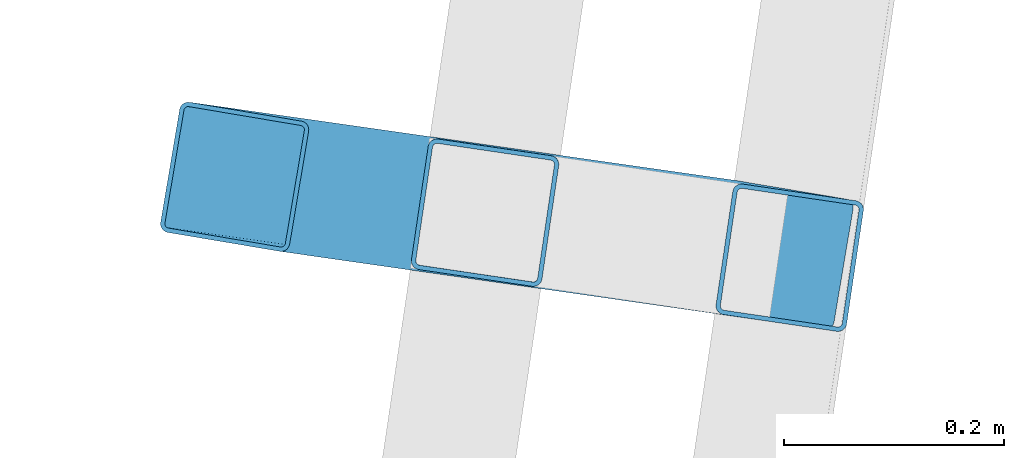
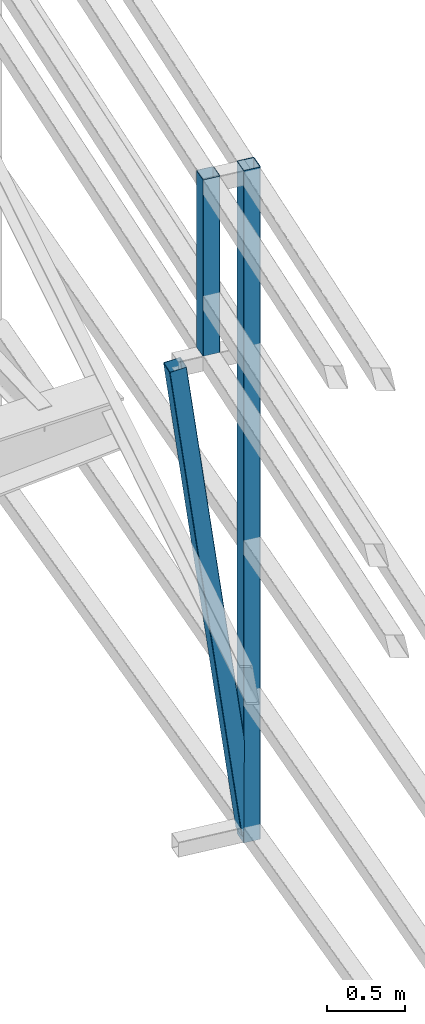
# One storey, part 124 of 215: 2 beams, 1 member, 3 elements without a shape of their own.
"""IFC2X3 building model written with IfcOpenShell, lengths in millimetres."""

from ifc_helpers import new_model, si_unit, frame, origin_with_axes, origin_2d_with_axis, place, context, subcontext, project, spatial, hollow_rectangle, extrude, material, type_object, element, aggregate, save


model = new_model("IFC2X3")

# Units and contexts
model_context = context("Model", 3, precision=1e-05, world=origin_with_axes())
body_context = subcontext(model_context, "Body", "Model", "MODEL_VIEW")
ifc_project = project(units=[si_unit("LENGTHUNIT", "METRE", prefix="MILLI"), si_unit("AREAUNIT", "SQUARE_METRE"), si_unit("VOLUMEUNIT", "CUBIC_METRE"), si_unit("MASSUNIT", "GRAM", prefix="KILO"), si_unit("TIMEUNIT", "SECOND"), si_unit("PLANEANGLEUNIT", "RADIAN"), si_unit("SOLIDANGLEUNIT", "STERADIAN"), si_unit("THERMODYNAMICTEMPERATUREUNIT", "DEGREE_CELSIUS"), si_unit("LUMINOUSINTENSITYUNIT", "LUMEN")], contexts=[model_context])

# Site, building, storey
site_placement = place(None, origin_with_axes())
site = spatial("IfcSite", under=ifc_project, at=site_placement, CompositionType="ELEMENT")
building_placement = place(site_placement, origin_with_axes())
building = spatial("IfcBuilding", under=site, at=building_placement, Name="Undefined", CompositionType="ELEMENT")
storey_placement = place(building_placement, origin_with_axes())
storey = spatial("IfcBuildingStorey", under=building, at=storey_placement, Name="Undefined", CompositionType="ELEMENT", Elevation=0.0)

# Assembly, beam
assembly_1_placement = place(storey_placement, origin_with_axes())
assembly_1 = element("IfcElementAssembly", 1, at=assembly_1_placement, inside=storey, Name="Steel Assembly", AssemblyPlace="NOTDEFINED", PredefinedType="RIGID_FRAME")
ifc_material = material(Name="STEEL/S275JR")
beam_type = type_object("IfcBeamType", PredefinedType="NOTDEFINED")
beam_1_placement = place(assembly_1_placement, frame((153218.497493034, 62408.8072456435, 5582.07346282597), z_axis=(0.989259672851491, -0.146168736978062, 0.0), x_axis=(9.50699999125844e-06, 6.43569999946843e-05, -0.999999997883897)))
beam_1 = element("IfcBeam", 2, at=beam_1_placement, type_object=beam_type, material=ifc_material, Name="LISSE", context=body_context, shape_type="SweptSolid", body=[
    extrude(hollow_rectangle(XDim=120.0, YDim=120.0, WallThickness=4.0, InnerFilletRadius=4.0, OuterFilletRadius=8.0, at=origin_2d_with_axis()), frame((1383.43541020251, -1.87490459654367e-17, 3.97204214758489e-18), z_axis=(-1.0, 0.0, 0.0), x_axis=(-6.93889390390723e-18, -1.0, -3.46944695195361e-18)), (0.0, 0.0, 1.0), 1383.4),
])
aggregate(assembly_1, [beam_1])

assembly_2_placement = place(storey_placement, origin_with_axes())
assembly_2 = element("IfcElementAssembly", 3, at=assembly_2_placement, inside=storey, Name="Steel Assembly", AssemblyPlace="NOTDEFINED", PredefinedType="RIGID_FRAME")
beam_2_placement = place(assembly_2_placement, frame((153495.485152215, 62367.8818838379, 5582.07345771888), z_axis=(0.989259672851491, -0.146168736978062, 0.0), x_axis=(0.0, 0.0, -1.0)))
beam_2 = element("IfcBeam", 4, at=beam_2_placement, type_object=beam_type, material=ifc_material, Name="LISSE", context=body_context, shape_type="SweptSolid", body=[
    extrude(hollow_rectangle(XDim=120.0, YDim=120.0, WallThickness=4.0, InnerFilletRadius=4.0, OuterFilletRadius=8.0, at=origin_2d_with_axis()), frame((5271.47024798367, 0.0, 0.0), z_axis=(-1.0, 0.0, 0.0), x_axis=(-6.93889390390723e-18, -1.0, -3.46944695195361e-18)), (0.0, 0.0, 1.0), 5271.5),
])
aggregate(assembly_2, [beam_2])

# Assembly, member
assembly_3_placement = place(storey_placement, origin_with_axes())
assembly_3 = element("IfcElementAssembly", 5, at=assembly_3_placement, inside=storey, Name="Steel Assembly", AssemblyPlace="NOTDEFINED", PredefinedType="RIGID_FRAME")
member_type = type_object("IfcMemberType", PredefinedType="NOTDEFINED")
member_placement = place(assembly_3_placement, frame((153485.789304556, 62370.6115388793, 370.603214711808), z_axis=(0.977519721024776, -0.164800514004181, 0.131514203003335), x_axis=(-0.130227987007616, 0.0186333370010904, 0.991308968057965)))
member = element("IfcMember", 6, at=member_placement, type_object=member_type, material=ifc_material, Name="LISSE", context=body_context, shape_type="SweptSolid", body=[
    extrude(hollow_rectangle(XDim=120.0, YDim=120.0, WallThickness=4.0, InnerFilletRadius=4.0, OuterFilletRadius=8.0, at=origin_2d_with_axis()), frame((3801.07006253403, 0.0, -1.05500887540967e-13), z_axis=(-1.0, 0.0, 0.0), x_axis=(-6.93889390390723e-18, -1.0, -3.46944695195361e-18)), (0.0, 0.0, 1.0), 3801.1),
])
aggregate(assembly_3, [member])

save(model, "model.ifc")
